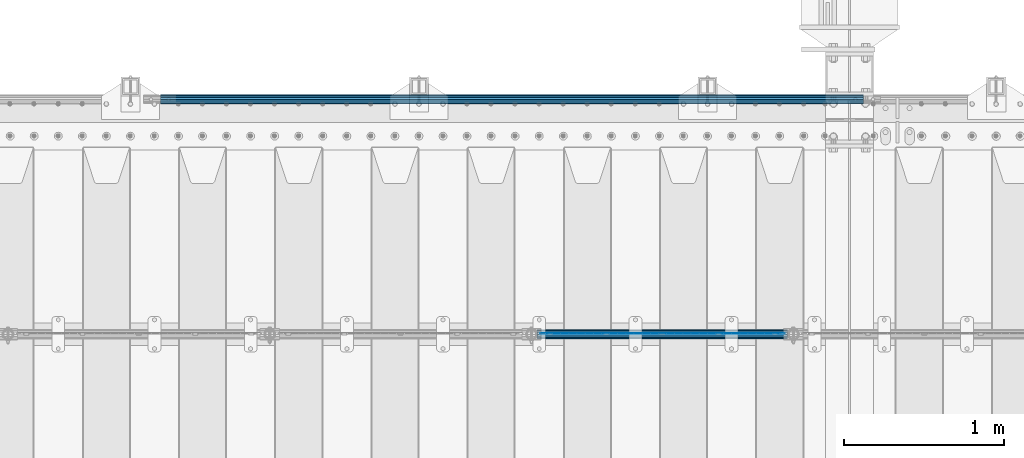
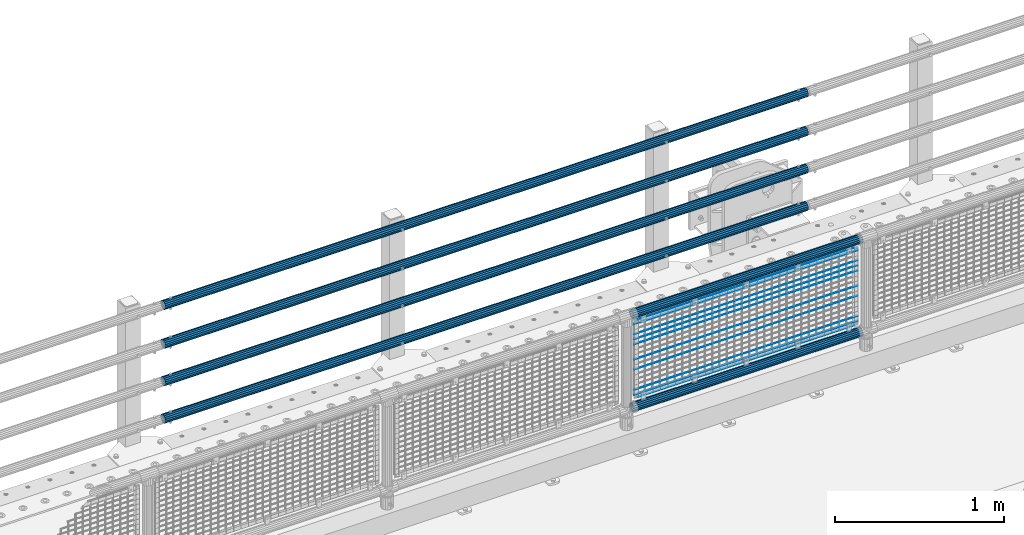
# One storey, part 136 of 270: 16 beams.
"""IFC2X3 building model written with IfcOpenShell, lengths in millimetres."""

import ifcopenshell
import ifcopenshell.guid

model = None  # the IFC model being written
_history = None  # IfcOwnerHistory: only IFC2X3 demands one
_inside = {}  # id of a spatial element -> (the spatial element, [elements in it])
_under = {}  # id of a project, library or spatial element -> (it, [spatial elements below it])
_declared = {}  # id of a project -> (the project, [libraries it declares])
_typed = {}  # id of a type object -> (the type object, [elements of that type])
_made_of = {}  # id of a material, layer set ... -> (it, [elements and type objects made of it])


def new_model(schema):
    """Start an empty IFC model of exactly this schema.

    Asked for "IFC4X3", IfcOpenShell would pick the latest addendum, in which some entities
    have other attributes; the version numbers below select the first issue.
    IFC2X3 requires an IfcOwnerHistory on every rooted entity: one is made here for all.
    """
    global model, _history
    if schema == "IFC4X3":
        model = ifcopenshell.file(schema_version=(4, 3, 0, 0))
    else:
        model = ifcopenshell.file(schema=schema)
    _inside.clear()
    _under.clear()
    _declared.clear()
    _typed.clear()
    _made_of.clear()
    _history = None
    if model.schema == "IFC2X3":
        org = make("IfcOrganization", Name="unknown")
        user = make(
            "IfcPersonAndOrganization",
            ThePerson=make("IfcPerson", FamilyName="unknown"),
            TheOrganization=org,
        )
        app = make(
            "IfcApplication",
            ApplicationDeveloper=org,
            Version="unknown",
            ApplicationFullName="unknown",
            ApplicationIdentifier="unknown",
        )
        _history = make(
            "IfcOwnerHistory",
            OwningUser=user,
            OwningApplication=app,
            ChangeAction="ADDED",
            CreationDate=0,
        )
    return model


def make(cls, **values):
    """One entity of the class cls with the attributes given. An attribute that is None is left unset."""
    return model.create_entity(
        cls, **{name: value for name, value in values.items() if value is not None}
    )


def rooted(cls, **values):
    """An entity with a GlobalId (a new one), such as an element, a storey or a relation."""
    return make(cls, GlobalId=ifcopenshell.guid.new(), OwnerHistory=_history, **values)


def si_unit(unit_type, name, prefix=None):
    """IfcSIUnit, for example si_unit("LENGTHUNIT", "METRE", prefix="MILLI")."""
    return make("IfcSIUnit", UnitType=unit_type, Prefix=prefix, Name=name)


def assignment(units):
    """IfcUnitAssignment: the units of a project."""
    return None if units is None else make("IfcUnitAssignment", Units=units)


def point(xyz):
    """IfcCartesianPoint."""
    return None if xyz is None else make("IfcCartesianPoint", Coordinates=xyz)


def direction(xyz):
    """IfcDirection."""
    return None if xyz is None else make("IfcDirection", DirectionRatios=xyz)


def frame(location, z_axis=None, x_axis=None):
    """IfcAxis2Placement3D, a coordinate frame: its origin and axes. An axis left out is left unset."""
    return make(
        "IfcAxis2Placement3D",
        Location=point(location),
        Axis=direction(z_axis),
        RefDirection=direction(x_axis),
    )


def origin_with_axes():
    """The frame at (0, 0, 0) with the z axis (0, 0, 1) and the x axis (1, 0, 0) written out."""
    return frame((0.0, 0.0, 0.0), z_axis=(0.0, 0.0, 1.0), x_axis=(1.0, 0.0, 0.0))


def place(relative_to, where):
    """IfcLocalPlacement: puts the frame where relative to a parent placement (None: the world)."""
    return make(
        "IfcLocalPlacement", PlacementRelTo=relative_to, RelativePlacement=where
    )


def context(
    kind, dimensions, precision=None, world=None, true_north=None, identifier=None
):
    """IfcGeometricRepresentationContext, for example the 3D "Model" context."""
    return make(
        "IfcGeometricRepresentationContext",
        ContextIdentifier=identifier,
        ContextType=kind,
        CoordinateSpaceDimension=dimensions,
        Precision=precision,
        WorldCoordinateSystem=world,
        TrueNorth=true_north,
    )


def subcontext(parent, identifier, kind, view, scale=None):
    """IfcGeometricRepresentationSubContext, for example "Body" below "Model"."""
    return make(
        "IfcGeometricRepresentationSubContext",
        ContextIdentifier=identifier,
        ContextType=kind,
        ParentContext=parent,
        TargetScale=scale,
        TargetView=view,
    )


def project(units=None, contexts=None):
    """IfcProject with its units and contexts."""
    return rooted(
        "IfcProject",
        Name="project",
        RepresentationContexts=contexts,
        UnitsInContext=assignment(units),
    )


def spatial(cls, under=None, at=None, **own):
    """A site, building, storey or space (cls), placed at a placement, below another one or the project."""
    s = rooted(cls, ObjectPlacement=at, **own)
    if under is not None:
        _under.setdefault(under.id(), (under, []))[1].append(s)
    return s


def faces_of(points, faces, orient=None, outer=None):
    """IfcFace entities. A face is a list of loops; a loop is a list of indices into points, from 0.

    orient and outer hold one flag for each loop. By default every Orientation is true, the
    first loop of a face is its IfcFaceOuterBound and the others are IfcFaceBound.
    """
    made = []
    for i, loops in enumerate(faces):
        bounds = []
        for j, loop in enumerate(loops):
            is_outer = j == 0 if outer is None else outer[i][j]
            bounds.append(
                make(
                    "IfcFaceOuterBound" if is_outer else "IfcFaceBound",
                    Bound=make("IfcPolyLoop", Polygon=[points[k] for k in loop]),
                    Orientation=True if orient is None else orient[i][j],
                )
            )
        made.append(make("IfcFace", Bounds=bounds))
    return made


def faceted_brep(points, faces, orient=None, outer=None, voids=None):
    """IfcFacetedBrep: a solid bounded by flat faces; with voids (closed shells), ...WithVoids."""
    shared = [point(p) for p in points]
    hull = make("IfcClosedShell", CfsFaces=faces_of(shared, faces, orient, outer))
    if voids is None:
        return make("IfcFacetedBrep", Outer=hull)
    return make(
        "IfcFacetedBrepWithVoids",
        Outer=hull,
        Voids=[
            make(cls, CfsFaces=faces_of(shared, fs, o, b)) for cls, fs, o, b in voids
        ],
    )


def shape(context_of_items, identifier, shape_type, items):
    """IfcShapeRepresentation: the items that make up one representation, for example the "Body"."""
    return make(
        "IfcShapeRepresentation",
        ContextOfItems=context_of_items,
        RepresentationIdentifier=identifier,
        RepresentationType=shape_type,
        Items=items,
    )


def material(Name=None, Category=None):
    """IfcMaterial."""
    return make("IfcMaterial", Name=Name, Category=Category)


def made_of(thing, what):
    """Note that an element or type object is made of a material, layer set ...; save() writes the relation."""
    if what is not None:
        _made_of.setdefault(what.id(), (what, []))[1].append(thing)
    return thing


def type_object(cls, material=None, **own):
    """A type object (cls), such as IfcWallType, which elements share."""
    return made_of(rooted(cls, **own), material)


def element(
    cls,
    number,
    at=None,
    inside=None,
    cuts=None,
    type_object=None,
    material=None,
    context=None,
    identifier="Body",
    shape_type=None,
    held_by="IfcProductDefinitionShape",
    body=None,
    shapes=None,
    **own,
):
    """One element of the class cls, such as IfcWall. Its Tag is "e" and its number.

    at: its placement. inside: the storey or other place that contains it. cuts: it is an
    opening in that element (IfcRelVoidsElement). A single representation is given by context,
    identifier, shape_type and body (its items); several are given by shapes. held_by: the class
    of the entity that holds the representations. save() writes the other relations.
    """
    e = rooted(cls, Tag="e%d" % number, ObjectPlacement=at, **own)
    if body is not None:
        shapes = [shape(context, identifier, shape_type, body)]
    if shapes is not None:
        e.Representation = make(held_by, Representations=shapes)
    if inside is not None:
        _inside.setdefault(inside.id(), (inside, []))[1].append(e)
    if cuts is not None:
        rooted(
            "IfcRelVoidsElement", RelatingBuildingElement=cuts, RelatedOpeningElement=e
        )
    if type_object is not None:
        _typed.setdefault(type_object.id(), (type_object, []))[1].append(e)
    return made_of(e, material)


def aggregate(whole, parts):
    """IfcRelAggregates: a whole, such as a stair, and the parts it consists of."""
    return rooted("IfcRelAggregates", RelatingObject=whole, RelatedObjects=parts)


def save(model, path):
    """Write the relations noted so far, then the file.

    IfcRelAggregates (storeys below a building ...), IfcRelContainedInSpatialStructure (elements
    in a storey), IfcRelDefinesByType, IfcRelAssociatesMaterial and IfcRelDeclares: one each for
    every whole, place, type object, material and project.
    """
    for whole, parts in _under.values():
        aggregate(whole, parts)
    for where, things in _inside.values():
        rooted(
            "IfcRelContainedInSpatialStructure",
            RelatedElements=things,
            RelatingStructure=where,
        )
    for kind, things in _typed.values():
        rooted("IfcRelDefinesByType", RelatedObjects=things, RelatingType=kind)
    for what, things in _made_of.values():
        rooted("IfcRelAssociatesMaterial", RelatedObjects=things, RelatingMaterial=what)
    for by, libraries in _declared.values():
        rooted("IfcRelDeclares", RelatingContext=by, RelatedDefinitions=libraries)
    model.write(path)


model = new_model("IFC2X3")

# Units and contexts
model_context = context("Model", 3, precision=1e-05, world=origin_with_axes())
body_context = subcontext(model_context, "Body", "Model", "MODEL_VIEW")
ifc_project = project(units=[si_unit("LENGTHUNIT", "METRE", prefix="MILLI"), si_unit("AREAUNIT", "SQUARE_METRE"), si_unit("VOLUMEUNIT", "CUBIC_METRE"), si_unit("MASSUNIT", "GRAM", prefix="KILO"), si_unit("TIMEUNIT", "SECOND"), si_unit("PLANEANGLEUNIT", "RADIAN"), si_unit("SOLIDANGLEUNIT", "STERADIAN"), si_unit("THERMODYNAMICTEMPERATUREUNIT", "DEGREE_CELSIUS"), si_unit("LUMINOUSINTENSITYUNIT", "LUMEN")], contexts=[model_context])

# Site, building, storey
site_placement = place(None, origin_with_axes())
site = spatial("IfcSite", under=ifc_project, at=site_placement, CompositionType="ELEMENT")
building_placement = place(site_placement, origin_with_axes())
building = spatial("IfcBuilding", under=site, at=building_placement, Name="Standard", CompositionType="ELEMENT")
storey_placement = place(building_placement, origin_with_axes())
storey = spatial("IfcBuildingStorey", under=building, at=storey_placement, Name="Undefined", CompositionType="ELEMENT", Elevation=0.0)

# Beams
ifc_material_1 = material()
beam_type_1 = type_object("IfcBeamType", PredefinedType="NOTDEFINED")
beam_1_placement = place(storey_placement, frame((14121.9999999999, -14870.1499999998, 149.849999999726), z_axis=(0.0, 0.0, -1.0), x_axis=(-1.0, 0.0, 0.0)))
element("IfcBeam", 1, at=beam_1_placement, inside=storey, type_object=beam_type_1, material=ifc_material_1, context=body_context, shape_type="Brep", body=[
    faceted_brep([(0.0, -26.5499999999993, 0.0), (0.0, -24.5290015881747, 10.1602451292931), (4384.0, -24.5290015881747, 10.1602451292931), (4384.0, -26.5499999999993, 0.0), (0.0, -18.7736850405036, 18.7736850405028), (4384.0, -18.7736850405036, 18.7736850405028), (0.0, -10.1602451292929, 24.5290015881747), (4384.0, -10.1602451292929, 24.5290015881747), (0.0, 0.0, 26.55), (4384.0, 0.0, 26.55), (0.0, 10.1602451292929, 24.5290015881747), (4384.0, 10.1602451292929, 24.5290015881747), (0.0, 18.7736850405036, 18.7736850405028), (4384.0, 18.7736850405036, 18.7736850405028), (0.0, 24.5290015881747, 10.1602451292931), (4384.0, 24.5290015881747, 10.1602451292931), (0.0, 26.5499999999993, 0.0), (4384.0, 26.5499999999993, 0.0), (0.0, 24.5290015881747, -10.1602451292931), (4384.0, 24.5290015881747, -10.1602451292931), (0.0, 18.7736850405036, -18.7736850405028), (4384.0, 18.7736850405036, -18.7736850405028), (0.0, 10.1602451292929, -24.5290015881747), (4384.0, 10.1602451292929, -24.5290015881747), (0.0, 0.0, -26.55), (4384.0, 0.0, -26.55), (0.0, -10.1602451292929, -24.5290015881747), (4384.0, -10.1602451292929, -24.5290015881747), (0.0, -18.7736850405036, -18.7736850405028), (4384.0, -18.7736850405036, -18.7736850405028), (0.0, -24.5290015881747, -10.1602451292931), (4384.0, -24.5290015881747, -10.1602451292931), (0.0, -30.1499999999996, 0.0), (0.0, -27.8549679052157, -11.5379054858058), (4384.0, -27.8549679052157, -11.5379054858075), (4384.0, -30.1499999999996, 0.0), (0.0, -21.3192694527752, -21.3192694527752), (4384.0, -21.3192694527752, -21.3192694527744), (0.0, -11.5379054858076, -27.8549679052157), (4384.0, -11.5379054858076, -27.8549679052153), (0.0, 0.0, -30.1500000000015), (4384.0, 0.0, -30.15), (0.0, 11.5379054858076, -27.8549679052157), (4384.0, 11.5379054858076, -27.8549679052153), (0.0, 21.3192694527752, -21.3192694527752), (4384.0, 21.3192694527752, -21.3192694527744), (0.0, 27.8549679052157, -11.5379054858058), (4384.0, 27.8549679052157, -11.5379054858074), (0.0, 30.1499999999996, 0.0), (4384.0, 30.1499999999996, 0.0), (0.0, 27.8549679052157, 11.5379054858058), (4384.0, 27.8549679052157, 11.5379054858075), (0.0, 21.3192694527752, 21.3192694527752), (4384.0, 21.3192694527752, 21.3192694527744), (0.0, 11.5379054858076, 27.8549679052157), (4384.0, 11.5379054858076, 27.8549679052153), (0.0, 0.0, 30.1500000000015), (4384.0, 0.0, 30.15), (0.0, -11.5379054858076, 27.8549679052157), (4384.0, -11.5379054858076, 27.8549679052153), (0.0, -21.3192694527752, 21.3192694527752), (4384.0, -21.3192694527752, 21.3192694527744), (0.0, -27.8549679052157, 11.5379054858058), (4384.0, -27.8549679052157, 11.5379054858075)], [[[0, 1, 2, 3]], [[1, 4, 5, 2]], [[4, 6, 7, 5]], [[6, 8, 9, 7]], [[8, 10, 11, 9]], [[10, 12, 13, 11]], [[12, 14, 15, 13]], [[14, 16, 17, 15]], [[16, 18, 19, 17]], [[18, 20, 21, 19]], [[20, 22, 23, 21]], [[22, 24, 25, 23]], [[24, 26, 27, 25]], [[26, 28, 29, 27]], [[28, 30, 31, 29]], [[30, 0, 3, 31]], [[32, 33, 34, 35]], [[33, 36, 37, 34]], [[36, 38, 39, 37]], [[38, 40, 41, 39]], [[40, 42, 43, 41]], [[42, 44, 45, 43]], [[44, 46, 47, 45]], [[46, 48, 49, 47]], [[48, 50, 51, 49]], [[50, 52, 53, 51]], [[52, 54, 55, 53]], [[54, 56, 57, 55]], [[56, 58, 59, 57]], [[58, 60, 61, 59]], [[60, 62, 63, 61]], [[62, 32, 35, 63]], [[37, 39, 41, 43, 45, 47, 49, 51, 53, 55, 57, 59, 61, 63, 35, 34], [5, 7, 9, 11, 13, 15, 17, 19, 21, 23, 25, 27, 29, 31, 3, 2]], [[62, 60, 58, 56, 54, 52, 50, 48, 46, 44, 42, 40, 38, 36, 33, 32], [30, 28, 26, 24, 22, 20, 18, 16, 14, 12, 10, 8, 6, 4, 1, 0]]]),
])
beam_2_placement = place(storey_placement, frame((14121.9999999999, -14870.1499999998, 420.149999999729), z_axis=(0.0, 0.0, -1.0), x_axis=(-1.0, 0.0, 0.0)))
element("IfcBeam", 2, at=beam_2_placement, inside=storey, type_object=beam_type_1, material=ifc_material_1, context=body_context, shape_type="Brep", body=[
    faceted_brep([(0.0, -26.5499999999993, 0.0), (0.0, -24.5290015881747, 10.1602451292931), (4384.0, -24.5290015881747, 10.1602451292931), (4384.0, -26.5499999999993, 0.0), (0.0, -18.7736850405036, 18.7736850405028), (4384.0, -18.7736850405036, 18.7736850405028), (0.0, -10.1602451292929, 24.5290015881747), (4384.0, -10.1602451292929, 24.5290015881747), (0.0, 0.0, 26.55), (4384.0, 0.0, 26.55), (0.0, 10.1602451292929, 24.5290015881747), (4384.0, 10.1602451292929, 24.5290015881747), (0.0, 18.7736850405036, 18.7736850405028), (4384.0, 18.7736850405036, 18.7736850405028), (0.0, 24.5290015881747, 10.1602451292931), (4384.0, 24.5290015881747, 10.1602451292931), (0.0, 26.5499999999993, 0.0), (4384.0, 26.5499999999993, 0.0), (0.0, 24.5290015881747, -10.1602451292931), (4384.0, 24.5290015881747, -10.1602451292931), (0.0, 18.7736850405036, -18.7736850405028), (4384.0, 18.7736850405036, -18.7736850405028), (0.0, 10.1602451292929, -24.5290015881747), (4384.0, 10.1602451292929, -24.5290015881747), (0.0, 0.0, -26.55), (4384.0, 0.0, -26.55), (0.0, -10.1602451292929, -24.5290015881747), (4384.0, -10.1602451292929, -24.5290015881747), (0.0, -18.7736850405036, -18.7736850405028), (4384.0, -18.7736850405036, -18.7736850405028), (0.0, -24.5290015881747, -10.1602451292931), (4384.0, -24.5290015881747, -10.1602451292931), (0.0, -30.1499999999996, 0.0), (0.0, -27.8549679052157, -11.5379054858058), (4384.0, -27.8549679052157, -11.5379054858075), (4384.0, -30.1499999999996, 0.0), (0.0, -21.3192694527752, -21.3192694527752), (4384.0, -21.3192694527752, -21.3192694527744), (0.0, -11.5379054858076, -27.8549679052157), (4384.0, -11.5379054858076, -27.8549679052153), (0.0, 0.0, -30.1500000000015), (4384.0, 0.0, -30.15), (0.0, 11.5379054858076, -27.8549679052157), (4384.0, 11.5379054858076, -27.8549679052153), (0.0, 21.3192694527752, -21.3192694527752), (4384.0, 21.3192694527752, -21.3192694527744), (0.0, 27.8549679052157, -11.5379054858058), (4384.0, 27.8549679052157, -11.5379054858074), (0.0, 30.1499999999996, 0.0), (4384.0, 30.1499999999996, 0.0), (0.0, 27.8549679052157, 11.5379054858058), (4384.0, 27.8549679052157, 11.5379054858075), (0.0, 21.3192694527752, 21.3192694527752), (4384.0, 21.3192694527752, 21.3192694527744), (0.0, 11.5379054858076, 27.8549679052157), (4384.0, 11.5379054858076, 27.8549679052153), (0.0, 0.0, 30.1500000000015), (4384.0, 0.0, 30.15), (0.0, -11.5379054858076, 27.8549679052157), (4384.0, -11.5379054858076, 27.8549679052153), (0.0, -21.3192694527752, 21.3192694527752), (4384.0, -21.3192694527752, 21.3192694527744), (0.0, -27.8549679052157, 11.5379054858058), (4384.0, -27.8549679052157, 11.5379054858075)], [[[0, 1, 2, 3]], [[1, 4, 5, 2]], [[4, 6, 7, 5]], [[6, 8, 9, 7]], [[8, 10, 11, 9]], [[10, 12, 13, 11]], [[12, 14, 15, 13]], [[14, 16, 17, 15]], [[16, 18, 19, 17]], [[18, 20, 21, 19]], [[20, 22, 23, 21]], [[22, 24, 25, 23]], [[24, 26, 27, 25]], [[26, 28, 29, 27]], [[28, 30, 31, 29]], [[30, 0, 3, 31]], [[32, 33, 34, 35]], [[33, 36, 37, 34]], [[36, 38, 39, 37]], [[38, 40, 41, 39]], [[40, 42, 43, 41]], [[42, 44, 45, 43]], [[44, 46, 47, 45]], [[46, 48, 49, 47]], [[48, 50, 51, 49]], [[50, 52, 53, 51]], [[52, 54, 55, 53]], [[54, 56, 57, 55]], [[56, 58, 59, 57]], [[58, 60, 61, 59]], [[60, 62, 63, 61]], [[62, 32, 35, 63]], [[37, 39, 41, 43, 45, 47, 49, 51, 53, 55, 57, 59, 61, 63, 35, 34], [5, 7, 9, 11, 13, 15, 17, 19, 21, 23, 25, 27, 29, 31, 3, 2]], [[62, 60, 58, 56, 54, 52, 50, 48, 46, 44, 42, 40, 38, 36, 33, 32], [30, 28, 26, 24, 22, 20, 18, 16, 14, 12, 10, 8, 6, 4, 1, 0]]]),
])
beam_3_placement = place(storey_placement, frame((14121.9999999999, -14870.1499999998, 969.849999999726), z_axis=(0.0, 0.0, -1.0), x_axis=(-1.0, 0.0, 0.0)))
element("IfcBeam", 3, at=beam_3_placement, inside=storey, type_object=beam_type_1, material=ifc_material_1, context=body_context, shape_type="Brep", body=[
    faceted_brep([(0.0, -26.5499999999993, 0.0), (0.0, -24.5290015881747, 10.1602451292931), (4384.0, -24.5290015881747, 10.1602451292931), (4384.0, -26.5499999999993, 0.0), (0.0, -18.7736850405036, 18.7736850405028), (4384.0, -18.7736850405036, 18.7736850405028), (0.0, -10.1602451292929, 24.5290015881747), (4384.0, -10.1602451292929, 24.5290015881747), (0.0, 0.0, 26.55), (4384.0, 0.0, 26.55), (0.0, 10.1602451292929, 24.5290015881747), (4384.0, 10.1602451292929, 24.5290015881747), (0.0, 18.7736850405036, 18.7736850405028), (4384.0, 18.7736850405036, 18.7736850405028), (0.0, 24.5290015881747, 10.1602451292931), (4384.0, 24.5290015881747, 10.1602451292931), (0.0, 26.5499999999993, 0.0), (4384.0, 26.5499999999993, 0.0), (0.0, 24.5290015881747, -10.1602451292931), (4384.0, 24.5290015881747, -10.1602451292931), (0.0, 18.7736850405036, -18.7736850405028), (4384.0, 18.7736850405036, -18.7736850405028), (0.0, 10.1602451292929, -24.5290015881747), (4384.0, 10.1602451292929, -24.5290015881747), (0.0, 0.0, -26.55), (4384.0, 0.0, -26.55), (0.0, -10.1602451292929, -24.5290015881747), (4384.0, -10.1602451292929, -24.5290015881747), (0.0, -18.7736850405036, -18.7736850405028), (4384.0, -18.7736850405036, -18.7736850405028), (0.0, -24.5290015881747, -10.1602451292931), (4384.0, -24.5290015881747, -10.1602451292931), (0.0, -30.1499999999996, 0.0), (0.0, -27.8549679052157, -11.5379054858058), (4384.0, -27.8549679052157, -11.5379054858075), (4384.0, -30.1499999999996, 0.0), (0.0, -21.3192694527752, -21.3192694527752), (4384.0, -21.3192694527752, -21.3192694527744), (0.0, -11.5379054858076, -27.8549679052157), (4384.0, -11.5379054858076, -27.8549679052153), (0.0, 0.0, -30.1500000000015), (4384.0, 0.0, -30.15), (0.0, 11.5379054858076, -27.8549679052157), (4384.0, 11.5379054858076, -27.8549679052153), (0.0, 21.3192694527752, -21.3192694527752), (4384.0, 21.3192694527752, -21.3192694527744), (0.0, 27.8549679052157, -11.5379054858058), (4384.0, 27.8549679052157, -11.5379054858074), (0.0, 30.1499999999996, 0.0), (4384.0, 30.1499999999996, 0.0), (0.0, 27.8549679052157, 11.5379054858058), (4384.0, 27.8549679052157, 11.5379054858075), (0.0, 21.3192694527752, 21.3192694527752), (4384.0, 21.3192694527752, 21.3192694527744), (0.0, 11.5379054858076, 27.8549679052157), (4384.0, 11.5379054858076, 27.8549679052153), (0.0, 0.0, 30.1500000000015), (4384.0, 0.0, 30.15), (0.0, -11.5379054858076, 27.8549679052157), (4384.0, -11.5379054858076, 27.8549679052153), (0.0, -21.3192694527752, 21.3192694527752), (4384.0, -21.3192694527752, 21.3192694527744), (0.0, -27.8549679052157, 11.5379054858058), (4384.0, -27.8549679052157, 11.5379054858075)], [[[0, 1, 2, 3]], [[1, 4, 5, 2]], [[4, 6, 7, 5]], [[6, 8, 9, 7]], [[8, 10, 11, 9]], [[10, 12, 13, 11]], [[12, 14, 15, 13]], [[14, 16, 17, 15]], [[16, 18, 19, 17]], [[18, 20, 21, 19]], [[20, 22, 23, 21]], [[22, 24, 25, 23]], [[24, 26, 27, 25]], [[26, 28, 29, 27]], [[28, 30, 31, 29]], [[30, 0, 3, 31]], [[32, 33, 34, 35]], [[33, 36, 37, 34]], [[36, 38, 39, 37]], [[38, 40, 41, 39]], [[40, 42, 43, 41]], [[42, 44, 45, 43]], [[44, 46, 47, 45]], [[46, 48, 49, 47]], [[48, 50, 51, 49]], [[50, 52, 53, 51]], [[52, 54, 55, 53]], [[54, 56, 57, 55]], [[56, 58, 59, 57]], [[58, 60, 61, 59]], [[60, 62, 63, 61]], [[62, 32, 35, 63]], [[37, 39, 41, 43, 45, 47, 49, 51, 53, 55, 57, 59, 61, 63, 35, 34], [5, 7, 9, 11, 13, 15, 17, 19, 21, 23, 25, 27, 29, 31, 3, 2]], [[62, 60, 58, 56, 54, 52, 50, 48, 46, 44, 42, 40, 38, 36, 33, 32], [30, 28, 26, 24, 22, 20, 18, 16, 14, 12, 10, 8, 6, 4, 1, 0]]]),
])
beam_4_placement = place(storey_placement, frame((14121.9999999999, -14870.1499999998, 689.849999999726), z_axis=(0.0, 0.0, -1.0), x_axis=(-1.0, 0.0, 0.0)))
element("IfcBeam", 4, at=beam_4_placement, inside=storey, type_object=beam_type_1, material=ifc_material_1, context=body_context, shape_type="Brep", body=[
    faceted_brep([(0.0, -26.5499999999993, 0.0), (0.0, -24.5290015881747, 10.1602451292931), (4384.0, -24.5290015881747, 10.1602451292931), (4384.0, -26.5499999999993, 0.0), (0.0, -18.7736850405036, 18.7736850405028), (4384.0, -18.7736850405036, 18.7736850405028), (0.0, -10.1602451292929, 24.5290015881747), (4384.0, -10.1602451292929, 24.5290015881747), (0.0, 0.0, 26.55), (4384.0, 0.0, 26.55), (0.0, 10.1602451292929, 24.5290015881747), (4384.0, 10.1602451292929, 24.5290015881747), (0.0, 18.7736850405036, 18.7736850405028), (4384.0, 18.7736850405036, 18.7736850405028), (0.0, 24.5290015881747, 10.1602451292931), (4384.0, 24.5290015881747, 10.1602451292931), (0.0, 26.5499999999993, 0.0), (4384.0, 26.5499999999993, 0.0), (0.0, 24.5290015881747, -10.1602451292931), (4384.0, 24.5290015881747, -10.1602451292931), (0.0, 18.7736850405036, -18.7736850405028), (4384.0, 18.7736850405036, -18.7736850405028), (0.0, 10.1602451292929, -24.5290015881747), (4384.0, 10.1602451292929, -24.5290015881747), (0.0, 0.0, -26.55), (4384.0, 0.0, -26.55), (0.0, -10.1602451292929, -24.5290015881747), (4384.0, -10.1602451292929, -24.5290015881747), (0.0, -18.7736850405036, -18.7736850405028), (4384.0, -18.7736850405036, -18.7736850405028), (0.0, -24.5290015881747, -10.1602451292931), (4384.0, -24.5290015881747, -10.1602451292931), (0.0, -30.1499999999996, 0.0), (0.0, -27.8549679052157, -11.5379054858058), (4384.0, -27.8549679052157, -11.5379054858075), (4384.0, -30.1499999999996, 0.0), (0.0, -21.3192694527752, -21.3192694527752), (4384.0, -21.3192694527752, -21.3192694527744), (0.0, -11.5379054858076, -27.8549679052157), (4384.0, -11.5379054858076, -27.8549679052153), (0.0, 0.0, -30.1500000000015), (4384.0, 0.0, -30.15), (0.0, 11.5379054858076, -27.8549679052157), (4384.0, 11.5379054858076, -27.8549679052153), (0.0, 21.3192694527752, -21.3192694527752), (4384.0, 21.3192694527752, -21.3192694527744), (0.0, 27.8549679052157, -11.5379054858058), (4384.0, 27.8549679052157, -11.5379054858074), (0.0, 30.1499999999996, 0.0), (4384.0, 30.1499999999996, 0.0), (0.0, 27.8549679052157, 11.5379054858058), (4384.0, 27.8549679052157, 11.5379054858075), (0.0, 21.3192694527752, 21.3192694527752), (4384.0, 21.3192694527752, 21.3192694527744), (0.0, 11.5379054858076, 27.8549679052157), (4384.0, 11.5379054858076, 27.8549679052153), (0.0, 0.0, 30.1500000000015), (4384.0, 0.0, 30.15), (0.0, -11.5379054858076, 27.8549679052157), (4384.0, -11.5379054858076, 27.8549679052153), (0.0, -21.3192694527752, 21.3192694527752), (4384.0, -21.3192694527752, 21.3192694527744), (0.0, -27.8549679052157, 11.5379054858058), (4384.0, -27.8549679052157, 11.5379054858075)], [[[0, 1, 2, 3]], [[1, 4, 5, 2]], [[4, 6, 7, 5]], [[6, 8, 9, 7]], [[8, 10, 11, 9]], [[10, 12, 13, 11]], [[12, 14, 15, 13]], [[14, 16, 17, 15]], [[16, 18, 19, 17]], [[18, 20, 21, 19]], [[20, 22, 23, 21]], [[22, 24, 25, 23]], [[24, 26, 27, 25]], [[26, 28, 29, 27]], [[28, 30, 31, 29]], [[30, 0, 3, 31]], [[32, 33, 34, 35]], [[33, 36, 37, 34]], [[36, 38, 39, 37]], [[38, 40, 41, 39]], [[40, 42, 43, 41]], [[42, 44, 45, 43]], [[44, 46, 47, 45]], [[46, 48, 49, 47]], [[48, 50, 51, 49]], [[50, 52, 53, 51]], [[52, 54, 55, 53]], [[54, 56, 57, 55]], [[56, 58, 59, 57]], [[58, 60, 61, 59]], [[60, 62, 63, 61]], [[62, 32, 35, 63]], [[37, 39, 41, 43, 45, 47, 49, 51, 53, 55, 57, 59, 61, 63, 35, 34], [5, 7, 9, 11, 13, 15, 17, 19, 21, 23, 25, 27, 29, 31, 3, 2]], [[62, 60, 58, 56, 54, 52, 50, 48, 46, 44, 42, 40, 38, 36, 33, 32], [30, 28, 26, 24, 22, 20, 18, 16, 14, 12, 10, 8, 6, 4, 1, 0]]]),
])
ifc_material_2 = material(Name="Misc_Undefined")
beam_type_2 = type_object("IfcBeamType", Name="D3", PredefinedType="NOTDEFINED")
for number, where, z_axis, x_axis in (
    (5, (12107.0, -16329.5, 815.167999999999), (0.0, 0.0, 1.0), (1.0, 0.0, 0.0)),
    (6, (12107.0, -16329.5, 888.025999999999), (0.0, 0.0, 1.0), (1.0, 0.0, 0.0)),
    (7, (12107.0, -16329.5, 778.738999999999), (0.0, 0.0, 1.0), (1.0, 0.0, 0.0)),
    (8, (12107.0, -16329.5, 742.309999999999), (0.0, 0.0, 1.0), (1.0, 0.0, 0.0)),
    (9, (12107.0, -16329.5, 633.023), (0.0, 0.0, 1.0), (1.0, 0.0, 0.0)),
    (10, (12107.0, -16329.5, 560.165), (0.0, 0.0, 1.0), (1.0, 0.0, 0.0)),
    (11, (12107.0, -16329.5, 414.449), (0.0, 0.0, 1.0), (1.0, 0.0, 0.0)),
):
    element("IfcBeam", number, at=place(storey_placement, frame(where, z_axis=z_axis, x_axis=x_axis)), inside=storey, type_object=beam_type_2, material=ifc_material_2, ObjectType="D3", context=body_context, shape_type="Brep", body=[
        faceted_brep([(0.0, -1.5, 0.0), (0.0, -0.75, -1.29903810567669), (1523.0, -0.75, -1.29903810567669), (1523.0, -1.5, 0.0), (0.0, 0.75, -1.29903810567669), (1523.0, 0.75, -1.29903810567669), (0.0, 1.5, 0.0), (1523.0, 1.5, 0.0), (0.0, 0.75, 1.29903810567669), (1523.0, 0.75, 1.29903810567669), (0.0, -0.75, 1.29903810567669), (1523.0, -0.75, 1.29903810567669)], [[[0, 1, 2, 3]], [[1, 4, 5, 2]], [[4, 6, 7, 5]], [[6, 8, 9, 7]], [[8, 10, 11, 9]], [[10, 0, 3, 11]], [[5, 7, 9, 11, 3, 2]], [[10, 8, 6, 4, 1, 0]]]),
    ])
beam_5_placement = place(storey_placement, frame((12132.0, -16329.5, 353.02), z_axis=(0.0, 0.0, 1.0), x_axis=(1.0, 0.0, 0.0)))
element("IfcBeam", 12, at=beam_5_placement, inside=storey, type_object=beam_type_2, material=ifc_material_2, ObjectType="D3", context=body_context, shape_type="Brep", body=[
    faceted_brep([(0.0, -1.5, 0.0), (0.0, -0.75, -1.29903810567669), (1473.0, -0.75, -1.29903810567669), (1473.0, -1.5, 0.0), (0.0, 0.75, -1.29903810567669), (1473.0, 0.75, -1.29903810567663), (0.0, 1.5, 0.0), (1473.0, 1.5, 0.0), (0.0, 0.75, 1.29903810567669), (1473.0, 0.75, 1.29903810567669), (0.0, -0.75, 1.29903810567669), (1473.0, -0.75, 1.29903810567669)], [[[0, 1, 2, 3]], [[1, 4, 5, 2]], [[4, 6, 7, 5]], [[6, 8, 9, 7]], [[8, 10, 11, 9]], [[10, 0, 3, 11]], [[5, 7, 9, 11, 3, 2]], [[10, 8, 6, 4, 1, 0]]]),
])
beam_6_placement = place(storey_placement, frame((12107.0, -16329.5, 378.02), z_axis=(0.0, 0.0, 1.0), x_axis=(1.0, 0.0, 0.0)))
element("IfcBeam", 13, at=beam_6_placement, inside=storey, type_object=beam_type_2, material=ifc_material_2, ObjectType="D3", context=body_context, shape_type="Brep", body=[
    faceted_brep([(0.0, -1.5, 0.0), (0.0, -0.75, -1.29903810567669), (1523.0, -0.75, -1.29903810567669), (1523.0, -1.5, 0.0), (0.0, 0.75, -1.29903810567669), (1523.0, 0.75, -1.29903810567669), (0.0, 1.5, 0.0), (1523.0, 1.5, 0.0), (0.0, 0.75, 1.29903810567669), (1523.0, 0.75, 1.29903810567669), (0.0, -0.75, 1.29903810567669), (1523.0, -0.75, 1.29903810567669)], [[[0, 1, 2, 3]], [[1, 4, 5, 2]], [[4, 6, 7, 5]], [[6, 8, 9, 7]], [[8, 10, 11, 9]], [[10, 0, 3, 11]], [[5, 7, 9, 11, 3, 2]], [[10, 8, 6, 4, 1, 0]]]),
])
beam_7_placement = place(storey_placement, frame((12132.0, -16329.5, 913.02), z_axis=(0.0, 0.0, 1.0), x_axis=(1.0, 0.0, 0.0)))
element("IfcBeam", 14, at=beam_7_placement, inside=storey, type_object=beam_type_2, material=ifc_material_2, ObjectType="D3", context=body_context, shape_type="Brep", body=[
    faceted_brep([(0.0, -1.5, 0.0), (0.0, -0.75, -1.29903810567669), (1473.0, -0.75, -1.29903810567669), (1473.0, -1.5, 0.0), (0.0, 0.75, -1.29903810567669), (1473.0, 0.75, -1.29903810567663), (0.0, 1.5, 0.0), (1473.0, 1.5, 0.0), (0.0, 0.75, 1.29903810567669), (1473.0, 0.75, 1.29903810567669), (0.0, -0.75, 1.29903810567669), (1473.0, -0.75, 1.29903810567669)], [[[0, 1, 2, 3]], [[1, 4, 5, 2]], [[4, 6, 7, 5]], [[6, 8, 9, 7]], [[8, 10, 11, 9]], [[10, 0, 3, 11]], [[5, 7, 9, 11, 3, 2]], [[10, 8, 6, 4, 1, 0]]]),
])
beam_type_3 = type_object("IfcBeamType", PredefinedType="NOTDEFINED")
beam_8_placement = place(storey_placement, frame((12086.85, -16335.5, 969.849999999999), z_axis=(0.0, 0.0, 1.0), x_axis=(1.0, 0.0, 0.0)))
element("IfcBeam", 15, at=beam_8_placement, inside=storey, type_object=beam_type_3, material=ifc_material_1, context=body_context, shape_type="Brep", body=[
    faceted_brep([(0.0, -25.3500000000004, 0.0), (0.0, -23.4203461491616, 9.70102501045403), (1563.0, -23.4203461491616, 9.70102501045506), (1563.0, -25.3500000000004, 0.0), (0.0, -17.9251569030785, 17.9251569030785), (1563.0, -17.9251569030785, 17.925156903079), (0.0, -9.70102501045585, 23.4203461491597), (1563.0, -9.70102501045585, 23.4203461491611), (0.0, 0.0, 25.3499999999985), (1563.0, 0.0, 25.35), (0.0, 9.70102501045585, 23.4203461491597), (1563.0, 9.70102501045585, 23.4203461491611), (0.0, 17.9251569030785, 17.9251569030785), (1563.0, 17.9251569030785, 17.925156903079), (0.0, 23.4203461491616, 9.70102501045403), (1563.0, 23.4203461491616, 9.70102501045506), (0.0, 25.3500000000004, 0.0), (1563.0, 25.3500000000004, 0.0), (0.0, 23.4203461491616, -9.70102501045403), (1563.0, 23.4203461491616, -9.70102501045506), (0.0, 17.9251569030785, -17.9251569030785), (1563.0, 17.9251569030785, -17.925156903079), (0.0, 9.70102501045585, -23.4203461491597), (1563.0, 9.70102501045585, -23.4203461491611), (0.0, 0.0, -25.3499999999985), (1563.0, 0.0, -25.35), (0.0, -9.70102501045585, -23.4203461491597), (1563.0, -9.70102501045585, -23.4203461491611), (0.0, -17.9251569030785, -17.9251569030785), (1563.0, -17.9251569030785, -17.925156903079), (0.0, -23.4203461491616, -9.70102501045403), (1563.0, -23.4203461491616, -9.70102501045506), (0.0, -30.1499999999996, 0.0), (0.0, -27.8549679052157, -11.5379054858058), (1563.0, -27.8549679052157, -11.5379054858075), (1563.0, -30.1499999999996, 0.0), (0.0, -21.3192694527752, -21.3192694527752), (1563.0, -21.3192694527752, -21.3192694527744), (0.0, -11.5379054858076, -27.8549679052157), (1563.0, -11.5379054858076, -27.8549679052153), (0.0, 0.0, -30.1500000000015), (1563.0, 0.0, -30.15), (0.0, 11.5379054858076, -27.8549679052157), (1563.0, 11.5379054858076, -27.8549679052153), (0.0, 21.3192694527752, -21.3192694527752), (1563.0, 21.3192694527752, -21.3192694527744), (0.0, 27.8549679052157, -11.5379054858058), (1563.0, 27.8549679052157, -11.5379054858074), (0.0, 30.1499999999996, 0.0), (1563.0, 30.1499999999996, 0.0), (0.0, 27.8549679052157, 11.5379054858058), (1563.0, 27.8549679052157, 11.5379054858074), (0.0, 21.3192694527752, 21.3192694527752), (1563.0, 21.3192694527752, 21.3192694527744), (0.0, 11.5379054858076, 27.8549679052157), (1563.0, 11.5379054858076, 27.8549679052153), (0.0, 0.0, 30.1500000000015), (1563.0, 0.0, 30.15), (0.0, -11.5379054858076, 27.8549679052157), (1563.0, -11.5379054858076, 27.8549679052153), (0.0, -21.3192694527752, 21.3192694527752), (1563.0, -21.3192694527752, 21.3192694527744), (0.0, -27.8549679052157, 11.5379054858058), (1563.0, -27.8549679052157, 11.5379054858074)], [[[0, 1, 2, 3]], [[1, 4, 5, 2]], [[4, 6, 7, 5]], [[6, 8, 9, 7]], [[8, 10, 11, 9]], [[10, 12, 13, 11]], [[12, 14, 15, 13]], [[14, 16, 17, 15]], [[16, 18, 19, 17]], [[18, 20, 21, 19]], [[20, 22, 23, 21]], [[22, 24, 25, 23]], [[24, 26, 27, 25]], [[26, 28, 29, 27]], [[28, 30, 31, 29]], [[30, 0, 3, 31]], [[32, 33, 34, 35]], [[33, 36, 37, 34]], [[36, 38, 39, 37]], [[38, 40, 41, 39]], [[40, 42, 43, 41]], [[42, 44, 45, 43]], [[44, 46, 47, 45]], [[46, 48, 49, 47]], [[48, 50, 51, 49]], [[50, 52, 53, 51]], [[52, 54, 55, 53]], [[54, 56, 57, 55]], [[56, 58, 59, 57]], [[58, 60, 61, 59]], [[60, 62, 63, 61]], [[62, 32, 35, 63]], [[37, 39, 41, 43, 45, 47, 49, 51, 53, 55, 57, 59, 61, 63, 35, 34], [5, 7, 9, 11, 13, 15, 17, 19, 21, 23, 25, 27, 29, 31, 3, 2]], [[62, 60, 58, 56, 54, 52, 50, 48, 46, 44, 42, 40, 38, 36, 33, 32], [30, 28, 26, 24, 22, 20, 18, 16, 14, 12, 10, 8, 6, 4, 1, 0]]]),
])
beam_9_placement = place(storey_placement, frame((12086.85, -16335.5, 298.170000000001), z_axis=(0.0, 0.0, 1.0), x_axis=(1.0, 0.0, 0.0)))
element("IfcBeam", 16, at=beam_9_placement, inside=storey, type_object=beam_type_3, material=ifc_material_1, context=body_context, shape_type="Brep", body=[
    faceted_brep([(0.0, -25.3500000000004, 0.0), (0.0, -23.4203461491616, 9.70102501045403), (1563.0, -23.4203461491616, 9.70102501045506), (1563.0, -25.3500000000004, 0.0), (0.0, -17.9251569030785, 17.9251569030785), (1563.0, -17.9251569030785, 17.925156903079), (0.0, -9.70102501045585, 23.4203461491597), (1563.0, -9.70102501045585, 23.4203461491611), (0.0, 0.0, 25.3499999999985), (1563.0, 0.0, 25.35), (0.0, 9.70102501045585, 23.4203461491597), (1563.0, 9.70102501045585, 23.4203461491611), (0.0, 17.9251569030785, 17.9251569030785), (1563.0, 17.9251569030785, 17.925156903079), (0.0, 23.4203461491616, 9.70102501045403), (1563.0, 23.4203461491616, 9.70102501045506), (0.0, 25.3500000000004, 0.0), (1563.0, 25.3500000000004, 0.0), (0.0, 23.4203461491616, -9.70102501045403), (1563.0, 23.4203461491616, -9.70102501045506), (0.0, 17.9251569030785, -17.9251569030785), (1563.0, 17.9251569030785, -17.925156903079), (0.0, 9.70102501045585, -23.4203461491597), (1563.0, 9.70102501045585, -23.4203461491611), (0.0, 0.0, -25.3499999999985), (1563.0, 0.0, -25.35), (0.0, -9.70102501045585, -23.4203461491597), (1563.0, -9.70102501045585, -23.4203461491611), (0.0, -17.9251569030785, -17.9251569030785), (1563.0, -17.9251569030785, -17.925156903079), (0.0, -23.4203461491616, -9.70102501045403), (1563.0, -23.4203461491616, -9.70102501045506), (0.0, -30.1499999999996, 0.0), (0.0, -27.8549679052157, -11.5379054858058), (1563.0, -27.8549679052157, -11.5379054858075), (1563.0, -30.1499999999996, 0.0), (0.0, -21.3192694527752, -21.3192694527752), (1563.0, -21.3192694527752, -21.3192694527744), (0.0, -11.5379054858076, -27.8549679052157), (1563.0, -11.5379054858076, -27.8549679052153), (0.0, 0.0, -30.1500000000015), (1563.0, 0.0, -30.15), (0.0, 11.5379054858076, -27.8549679052157), (1563.0, 11.5379054858076, -27.8549679052153), (0.0, 21.3192694527752, -21.3192694527752), (1563.0, 21.3192694527752, -21.3192694527744), (0.0, 27.8549679052157, -11.5379054858058), (1563.0, 27.8549679052157, -11.5379054858074), (0.0, 30.1499999999996, 0.0), (1563.0, 30.1499999999996, 0.0), (0.0, 27.8549679052157, 11.5379054858058), (1563.0, 27.8549679052157, 11.5379054858074), (0.0, 21.3192694527752, 21.3192694527752), (1563.0, 21.3192694527752, 21.3192694527744), (0.0, 11.5379054858076, 27.8549679052157), (1563.0, 11.5379054858076, 27.8549679052153), (0.0, 0.0, 30.1500000000015), (1563.0, 0.0, 30.15), (0.0, -11.5379054858076, 27.8549679052157), (1563.0, -11.5379054858076, 27.8549679052153), (0.0, -21.3192694527752, 21.3192694527752), (1563.0, -21.3192694527752, 21.3192694527744), (0.0, -27.8549679052157, 11.5379054858058), (1563.0, -27.8549679052157, 11.5379054858074)], [[[0, 1, 2, 3]], [[1, 4, 5, 2]], [[4, 6, 7, 5]], [[6, 8, 9, 7]], [[8, 10, 11, 9]], [[10, 12, 13, 11]], [[12, 14, 15, 13]], [[14, 16, 17, 15]], [[16, 18, 19, 17]], [[18, 20, 21, 19]], [[20, 22, 23, 21]], [[22, 24, 25, 23]], [[24, 26, 27, 25]], [[26, 28, 29, 27]], [[28, 30, 31, 29]], [[30, 0, 3, 31]], [[32, 33, 34, 35]], [[33, 36, 37, 34]], [[36, 38, 39, 37]], [[38, 40, 41, 39]], [[40, 42, 43, 41]], [[42, 44, 45, 43]], [[44, 46, 47, 45]], [[46, 48, 49, 47]], [[48, 50, 51, 49]], [[50, 52, 53, 51]], [[52, 54, 55, 53]], [[54, 56, 57, 55]], [[56, 58, 59, 57]], [[58, 60, 61, 59]], [[60, 62, 63, 61]], [[62, 32, 35, 63]], [[37, 39, 41, 43, 45, 47, 49, 51, 53, 55, 57, 59, 61, 63, 35, 34], [5, 7, 9, 11, 13, 15, 17, 19, 21, 23, 25, 27, 29, 31, 3, 2]], [[62, 60, 58, 56, 54, 52, 50, 48, 46, 44, 42, 40, 38, 36, 33, 32], [30, 28, 26, 24, 22, 20, 18, 16, 14, 12, 10, 8, 6, 4, 1, 0]]]),
])

save(model, "model.ifc")
